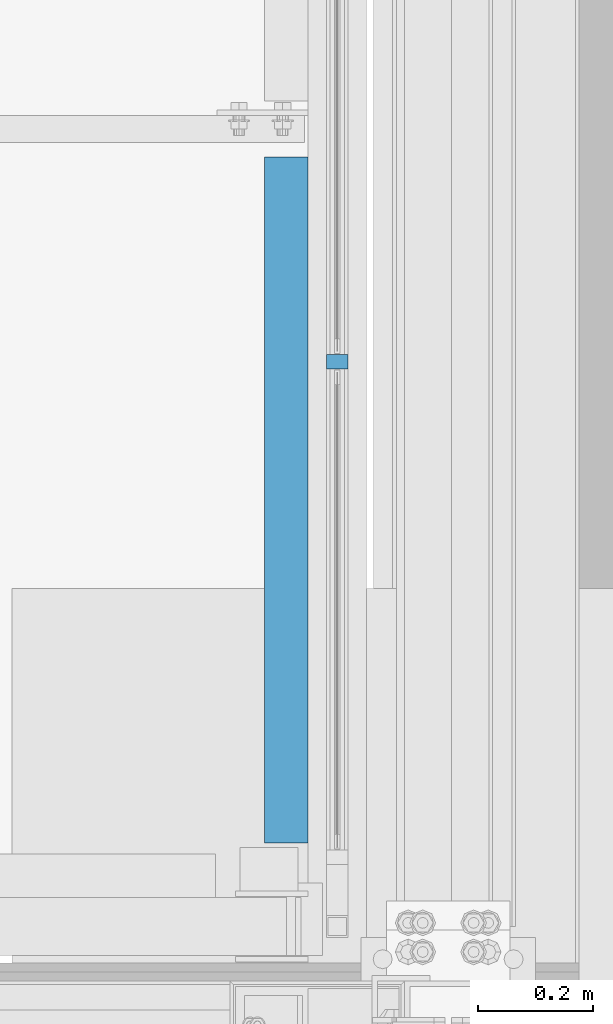
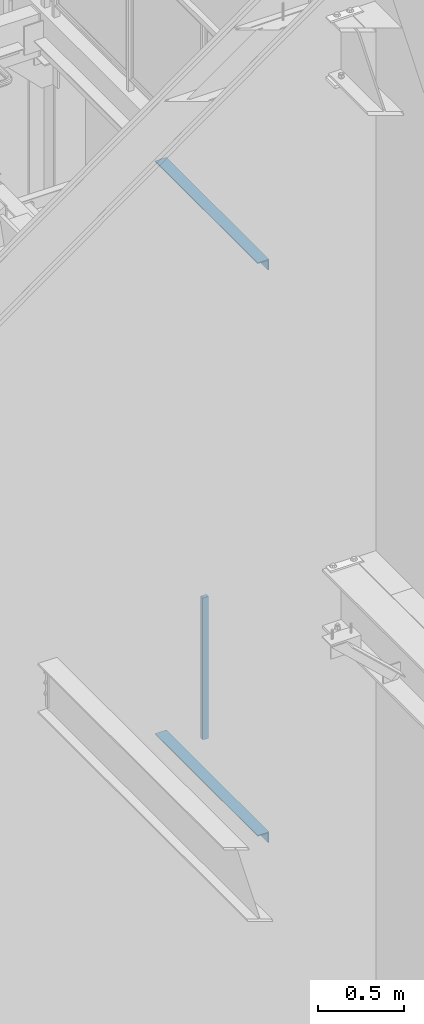
# One storey, part 788 of 1179: 2 beams, 1 member, 3 elements without a shape of their own.
"""IFC2X3 building model written with IfcOpenShell, lengths in millimetres."""

from ifc_helpers import new_model, si_unit, frame, origin_with_axes, place, context, subcontext, project, spatial, faceted_brep, material, type_object, element, aggregate, save


model = new_model("IFC2X3")

# Units and contexts
model_context = context("Model", 3, precision=1e-05, world=origin_with_axes())
body_context = subcontext(model_context, "Body", "Model", "MODEL_VIEW")
ifc_project = project(units=[si_unit("LENGTHUNIT", "METRE", prefix="MILLI"), si_unit("AREAUNIT", "SQUARE_METRE"), si_unit("VOLUMEUNIT", "CUBIC_METRE"), si_unit("MASSUNIT", "GRAM", prefix="KILO"), si_unit("TIMEUNIT", "SECOND"), si_unit("PLANEANGLEUNIT", "RADIAN"), si_unit("SOLIDANGLEUNIT", "STERADIAN"), si_unit("THERMODYNAMICTEMPERATUREUNIT", "DEGREE_CELSIUS"), si_unit("LUMINOUSINTENSITYUNIT", "LUMEN")], contexts=[model_context])

# Site, building, storey
site_placement = place(None, origin_with_axes())
site = spatial("IfcSite", under=ifc_project, at=site_placement, CompositionType="ELEMENT")
building_placement = place(site_placement, origin_with_axes())
building = spatial("IfcBuilding", under=site, at=building_placement, Name="Undefined", CompositionType="ELEMENT")
storey_placement = place(building_placement, origin_with_axes())
storey = spatial("IfcBuildingStorey", under=building, at=storey_placement, Name="Undefined", CompositionType="ELEMENT", Elevation=0.0)

# Assembly, member
assembly_1_placement = place(storey_placement, origin_with_axes())
assembly_1 = element("IfcElementAssembly", 1, at=assembly_1_placement, inside=storey, Name="GUARDRAIL", AssemblyPlace="NOTDEFINED", PredefinedType="RIGID_FRAME")
ifc_material = material(Name="STEEL/A36")
member_type = type_object("IfcMemberType", PredefinedType="NOTDEFINED")
member_placement = place(assembly_1_placement, frame((24114.1250004143, 39143.5166666676, 2155.82499951704), z_axis=(-1.0, 0.0, 0.0), x_axis=(0.0, 0.0, 1.0)))
member = element("IfcMember", 2, at=member_placement, type_object=member_type, material=ifc_material, Name="POST", context=body_context, shape_type="Brep", body=[
    faceted_brep([(0.0, 12.7000000000007, -19.0500000000029), (0.0, 12.7000000000007, 19.0500000000029), (1009.65000040151, 12.6999999999971, 19.0499999999993), (1009.65000040151, 12.6999999999971, -19.0499999999993), (0.0, -12.7000000000007, 19.0500000000029), (1009.65000040151, -12.6999999999971, 19.0499999999993), (0.0, -12.7000000000007, -19.0500000000029), (1009.65000040151, -12.6999999999971, -19.0499999999993)], [[[0, 1, 2, 3]], [[1, 4, 5, 2]], [[4, 6, 7, 5]], [[6, 0, 3, 7]], [[5, 7, 3, 2]], [[6, 4, 1, 0]]]),
])
aggregate(assembly_1, [member])

# Assembly, beam
assembly_2_placement = place(storey_placement, origin_with_axes())
assembly_2 = element("IfcElementAssembly", 3, at=assembly_2_placement, inside=storey, Name="BEAM", AssemblyPlace="NOTDEFINED", PredefinedType="RIGID_FRAME")
beam_type = type_object("IfcBeamType", Name="L3X3X1/4", PredefinedType="NOTDEFINED")
beam_1_placement = place(assembly_2_placement, frame((24025.225, 38303.1999999837, 6051.55), z_axis=(0.0, 0.0, -1.0), x_axis=(0.0, 1.0, 0.0)))
beam_1 = element("IfcBeam", 4, at=beam_1_placement, type_object=beam_type, material=ifc_material, Name="ANGLE", ObjectType="L3X3X1/4", context=body_context, shape_type="Brep", body=[
    faceted_brep([(0.0, 38.0999999999985, -38.0999999999999), (0.0, 38.0999999999985, 38.0999999999999), (1197.3718750163, 38.0999999999985, 38.1000000000004), (1197.3718750163, 38.0999999999985, -38.1000000000004), (0.0, 31.75, 38.1000000000004), (1197.3718750163, 31.75, 38.1000000000004), (0.0, 31.75, -31.75), (1197.3718750163, 31.75, -31.75), (0.0, -38.0999999999985, -31.75), (1197.3718750163, -38.0999999999985, -31.75), (0.0, -38.0999999999985, -38.0999999999999), (1197.3718750163, -38.0999999999985, -38.1000000000004)], [[[0, 1, 2, 3]], [[1, 4, 5, 2]], [[4, 6, 7, 5]], [[6, 8, 9, 7]], [[8, 10, 11, 9]], [[10, 0, 3, 11]], [[5, 7, 9, 11, 3, 2]], [[10, 8, 6, 4, 1, 0]]]),
])
aggregate(assembly_2, [beam_1])

assembly_3_placement = place(storey_placement, origin_with_axes())
assembly_3 = element("IfcElementAssembly", 5, at=assembly_3_placement, inside=storey, Name="BEAM", AssemblyPlace="NOTDEFINED", PredefinedType="RIGID_FRAME")
beam_2_placement = place(assembly_3_placement, frame((24025.2250004143, 38303.1999999837, 1978.025), z_axis=(0.0, 0.0, -1.0), x_axis=(0.0, 1.0, 0.0)))
beam_2 = element("IfcBeam", 6, at=beam_2_placement, type_object=beam_type, material=ifc_material, Name="ANGLE", ObjectType="L3X3X1/4", context=body_context, shape_type="Brep", body=[
    faceted_brep([(0.0, 38.0999999999985, -38.0999999999999), (0.0, 38.0999999999985, 38.0999999999999), (1197.3718750163, 38.0999999999985, 38.1000000000004), (1197.3718750163, 38.0999999999985, -38.1000000000004), (0.0, 31.75, 38.1000000000004), (1197.3718750163, 31.75, 38.1000000000004), (0.0, 31.75, -31.75), (1197.3718750163, 31.75, -31.75), (0.0, -38.0999999999985, -31.75), (1197.3718750163, -38.0999999999985, -31.75), (0.0, -38.0999999999985, -38.0999999999999), (1197.3718750163, -38.0999999999985, -38.1000000000004)], [[[0, 1, 2, 3]], [[1, 4, 5, 2]], [[4, 6, 7, 5]], [[6, 8, 9, 7]], [[8, 10, 11, 9]], [[10, 0, 3, 11]], [[5, 7, 9, 11, 3, 2]], [[10, 8, 6, 4, 1, 0]]]),
])
aggregate(assembly_3, [beam_2])

save(model, "model.ifc")
